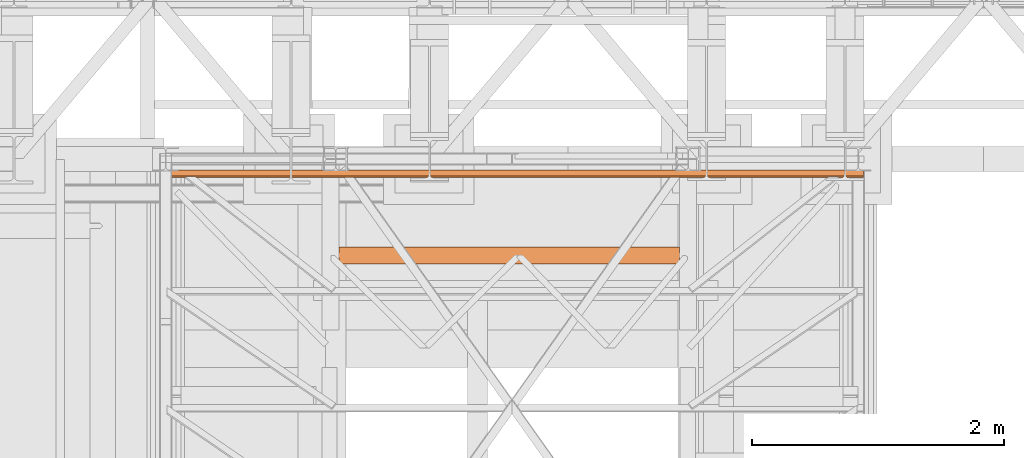
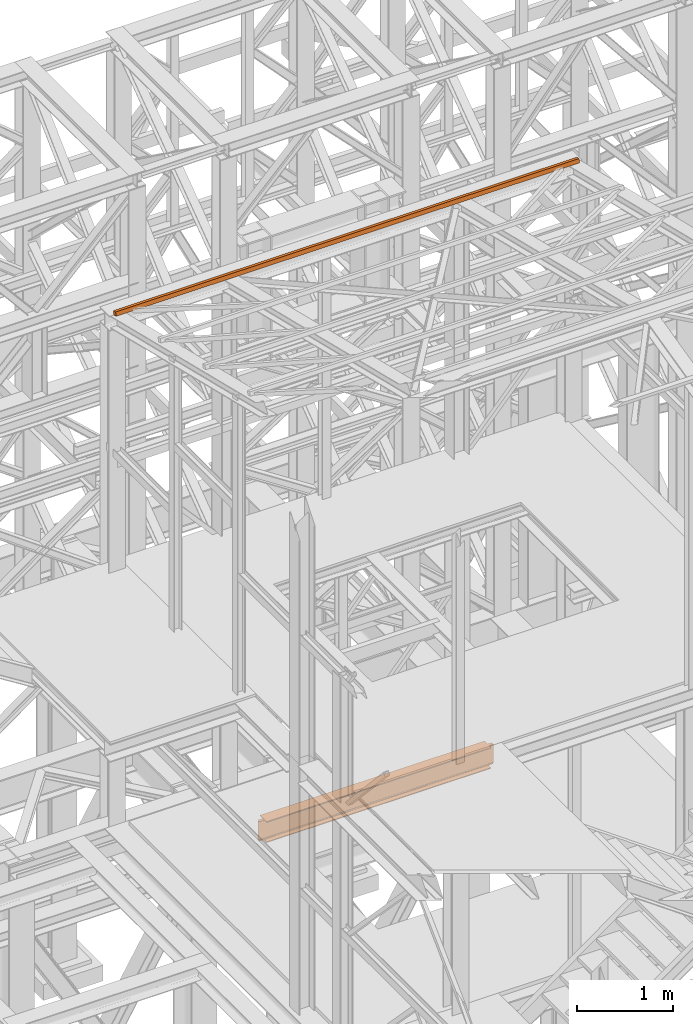
# One storey, part 73 of 208: 2 proxies.
"""IFC2X3 building model written with IfcOpenShell, lengths in millimetres."""

from ifc_helpers import new_model, entity, si_unit, converted_unit, frame, origin, origin_with_axes, place, context, subcontext, project, spatial, faceted_brep, element, save


model = new_model("IFC2X3")

# Units and contexts
model_context = context("Model", 3, precision=1e-05, world=origin())
plan_context = context("Plan", 3, precision=1e-05, world=origin())
body_context = subcontext(model_context, "Body", "Model", "MODEL_VIEW")
ifc_project = project(units=[si_unit("LENGTHUNIT", "METRE", prefix="MILLI"), converted_unit("PLANEANGLEUNIT", "DEGREE", entity("IfcPlaneAngleMeasure", 0.0174532925199433), si_unit("PLANEANGLEUNIT", "RADIAN"), dimensions=[0, 0, 0, 0, 0, 0, 0]), si_unit("AREAUNIT", "SQUARE_METRE"), si_unit("VOLUMEUNIT", "CUBIC_METRE")], contexts=[model_context, plan_context])

# Building, storey
building_placement = place(None, origin())
building = spatial("IfcBuilding", under=ifc_project, at=building_placement, CompositionType="COMPLEX")
storey_placement = place(building_placement, origin_with_axes())
storey = spatial("IfcBuildingStorey", under=building, at=storey_placement, Name="Geschoss", CompositionType="ELEMENT")

# Proxies
proxy_1_placement = place(storey_placement, frame((2509.054968290991, -18094.0743900329, 5014.990005364415), z_axis=(0.0, 0.0, 1.0), x_axis=(1.0, 0.0, 0.0)))
element("IfcBuildingElementProxy", 1, at=proxy_1_placement, inside=storey, context=body_context, shape_type="Brep", body=[
    faceted_brep([(2767.710000047684, 135.010000000002, 270.0100000000002), (64.21000004768393, 135.0100000000057, 270.0100000000002), (64.21000004768393, 135.0100000000057, 259.8100001907351), (2767.710000047684, 135.010000000002, 259.8100001907351), (2767.710000047684, 135.010000000002, 259.8100001907351), (64.21000004768393, 135.0100000000057, 259.8100001907351), (64.21000004768393, 85.80999995232196, 259.8100001907351), (2767.710000047684, 85.80999995231832, 259.8100001907351), (2816.910000095368, 85.80999995231832, 259.810000190736), (2767.710000047684, 85.80999995231832, 259.8100001907351), (64.21000004768393, 85.80999995232196, 259.8100001907351), (15.01000000000022, 85.80999995232196, 259.8100001907351), (10.37476080785564, 81.17476076017556, 259.0757968253238), (2821.545239287512, 81.17476076017556, 259.0757968253238), (2821.545239287512, 81.17476076017556, 259.0757968253238), (10.37476080785564, 81.17476076017556, 259.0757968253238), (6.193236074555898, 76.99323602687582, 256.9452365592933), (2825.726764020814, 76.99323602687582, 256.9452365592924), (2825.726764020814, 76.99323602687582, 256.9452365592924), (6.193236074555898, 76.99323602687582, 256.9452365592933), (2.874763631445603, 73.6747635837637, 253.6267641161803), (2829.045236463926, 73.6747635837637, 253.6267641161803), (2829.045236463926, 73.6747635837637, 253.6267641161803), (2.874763631445603, 73.6747635837637, 253.6267641161803), (0.7442033654115221, 71.54420331773144, 249.4452393828797), (2831.175796729956, 71.54420331773144, 249.4452393828797), (2831.175796729956, 71.54420331773144, 249.4452393828797), (0.7442033654115221, 71.54420331773144, 249.4452393828797), (0.01000000000021828, 70.80999995232196, 244.8100001907351), (2831.910000095368, 70.80999995231832, 244.8100001907351), (2831.910000095368, 70.80999995231832, 244.8100001907351), (0.01000000000021828, 70.80999995232196, 244.8100001907351), (0.01000000000021828, 70.80999995232196, 25.20999980926536), (2831.910000095368, 70.80999995231832, 25.20999980926536), (2831.910000095368, 70.80999995231832, 25.20999980926536), (0.01000000000021828, 70.80999995232196, 25.20999980926536), (0.7442033654115221, 71.54420331773144, 20.57476061712077), (2831.086954581584, 71.54420331773144, 20.57476061712077), (2831.398843532872, 71.42493642729096, 21.32772715327792), (2831.086954581584, 71.54420331773144, 20.57476061712077), (0.7442033654115221, 71.54420331773144, 20.57476061712077), (2.874763631443784, 73.6747635837637, 16.39323588382013), (2828.889959772629, 73.6747635837637, 16.39323588382013), (2829.900340863042, 73.00383809969208, 17.71002168452014), (2828.889959772629, 73.6747635837637, 16.39323588382013), (2.874763631443784, 73.6747635837637, 16.39323588382013), (6.193236074555898, 76.99323602687582, 13.07476344070892), (2825.524398651729, 76.99323602687582, 13.07476344070892), (2827.516601813166, 75.46460137611575, 14.60339809146717), (2825.524398651729, 76.99323602687582, 13.07476344070892), (6.193236074555898, 76.99323602687582, 13.07476344070892), (10.37476080785564, 81.17476076017556, 10.94420317467666), (2821.330755367998, 81.17476076017556, 10.94420317467666), (2824.409978220114, 78.67149890047949, 12.21965904159242), (2821.330755367998, 81.17476076017556, 10.94420317467666), (10.37476080785564, 81.17476076017556, 10.94420317467666), (15.01000000000022, 85.80999995232196, 10.20999980926536), (64.21000004768393, 85.80999995232196, 10.20999980926536), (2767.710000047684, 85.80999995231832, 10.20999980926536), (2816.910000095368, 85.80999995231832, 10.20999980926536), (2820.792272751356, 82.58292004036775, 10.72115637176194), (2767.710000047684, 85.80999995231832, 10.20999980926536), (64.21000004768393, 85.80999995232196, 10.20999980926536), (64.21000004768393, 135.0100000000057, 10.20999980926536), (2767.710000047684, 135.010000000002, 10.20999980926536), (2767.710000047684, 135.010000000002, 10.20999980926536), (64.21000004768393, 135.0100000000057, 10.20999980926536), (64.21000004768393, 135.0100000000057, 0.01000000000021828), (2767.710000047684, 135.010000000002, 0.01000000000021828), (2767.710000047684, 135.010000000002, 0.01000000000021828), (64.21000004768393, 135.0100000000057, 0.01000000000021828), (64.21000004768393, 0.01000000000567525, 0.01000000000021828), (2767.710000047684, 0.01000000000203727, 0.01000000000021828), (2767.710000047684, 0.01000000000203727, 0.01000000000021828), (64.21000004768393, 0.01000000000567525, 0.01000000000021828), (64.21000004768393, 0.01000000000567525, 10.20999980926536), (2767.710000047684, 0.01000000000203727, 10.20999980926536), (2767.710000047684, 0.01000000000203727, 10.20999980926536), (64.21000004768393, 0.01000000000567525, 10.20999980926536), (64.21000004768393, 49.21000004768939, 10.20999980926536), (2767.710000047684, 49.21000004768575, 10.20999980926536), (2816.910000095368, 49.21000004768575, 10.20999980926536), (2767.710000047684, 49.21000004768575, 10.20999980926536), (64.21000004768393, 49.21000004768939, 10.20999980926536), (15.01000000000022, 49.21000004768939, 10.20999980926536), (11.78292008804783, 53.0922727036741, 10.72115637176194), (2820.792272751355, 53.0922727036741, 10.72115637176194), (2820.792272751355, 53.0922727036741, 10.72115637176194), (11.78292008804783, 53.0922727036741, 10.72115637176194), (10.37476080785564, 53.63075532031871, 10.94420317467757), (7.871498948159569, 56.70997817243551, 12.21965904159242), (2824.409978220114, 56.70997817243188, 12.21965904159242), (2824.409978220114, 56.70997817243188, 12.21965904159242), (7.871498948159569, 56.70997817243551, 12.21965904159242), (6.193236074555898, 57.82439860405066, 13.07476344070892), (4.664601423799468, 59.81660176548758, 14.60339809146717), (2827.516601813166, 59.81660176548394, 14.60339809146717), (2827.516601813166, 59.81660176548394, 14.60339809146717), (4.664601423799468, 59.81660176548758, 14.60339809146717), (2.874763631443784, 61.18995972495031, 16.39323588382013), (2.203838147373972, 62.20034081536142, 17.71002168452014), (2829.900340863042, 62.20034081536142, 17.71002168452014), (2829.900340863042, 62.20034081536142, 17.71002168452014), (2.203838147373972, 62.20034081536142, 17.71002168452014), (0.7442033654115221, 63.38695453390392, 20.57476061712077), (0.6249364749728556, 63.6988434851919, 21.32772715327792), (2831.398843532872, 63.6988434851919, 21.32772715327792), (2831.398843532872, 63.6988434851919, 21.32772715327792), (0.6249364749728556, 63.6988434851919, 21.32772715327792), (0.01000000000021828, 64.21000004768939, 25.20999980926536), (2831.910000095368, 64.21000004768575, 25.20999980926536), (2831.910000095368, 64.21000004768575, 25.20999980926536), (0.01000000000021828, 64.21000004768939, 25.20999980926536), (0.01000000000021828, 64.21000004768939, 244.8100001907351), (2831.910000095368, 64.21000004768575, 244.8100001907351), (2831.910000095368, 64.21000004768575, 244.8100001907351), (0.01000000000021828, 64.21000004768939, 244.8100001907351), (0.7442033654115221, 63.47579668227627, 249.4452393828797), (2831.175796729956, 63.47579668227627, 249.4452393828797), (2831.175796729956, 63.47579668227627, 249.4452393828797), (0.7442033654115221, 63.47579668227627, 249.4452393828797), (2.874763631443784, 61.34523641624401, 253.6267641161803), (2829.045236463926, 61.34523641624401, 253.6267641161803), (2829.045236463926, 61.34523641624401, 253.6267641161803), (2.874763631443784, 61.34523641624401, 253.6267641161803), (6.193236074555898, 58.02676397313553, 256.9452365592933), (2825.726764020814, 58.02676397313189, 256.9452365592924), (2825.726764020814, 58.02676397313189, 256.9452365592924), (6.193236074555898, 58.02676397313553, 256.9452365592933), (10.37476080785564, 53.84523923983215, 259.0757968253238), (2821.545239287512, 53.84523923983215, 259.0757968253238), (2821.545239287512, 53.84523923983215, 259.0757968253238), (10.37476080785564, 53.84523923983215, 259.0757968253238), (15.01000000000022, 49.21000004768939, 259.8100001907351), (64.21000004768393, 49.21000004768939, 259.8100001907351), (2767.710000047684, 49.21000004768575, 259.8100001907351), (2816.910000095368, 49.21000004768575, 259.8100001907351), (2767.710000047684, 49.21000004768575, 259.8100001907351), (64.21000004768393, 49.21000004768939, 259.8100001907351), (64.21000004768393, 0.01000000000567525, 259.8100001907351), (2767.710000047684, 0.01000000000203727, 259.8100001907351), (2767.710000047684, 0.01000000000203727, 259.8100001907351), (64.21000004768393, 0.01000000000567525, 259.8100001907351), (64.21000004768393, 0.01000000000567525, 270.0100000000002), (2767.710000047684, 0.01000000000203727, 270.0100000000002), (2767.710000047684, 0.01000000000203727, 270.0100000000002), (64.21000004768393, 0.01000000000567525, 270.0100000000002), (64.21000004768393, 135.0100000000057, 270.0100000000002), (2767.710000047684, 135.010000000002, 270.0100000000002), (2767.710000047684, 0.01000000000203727, 0.01000000000021828), (2767.710000047684, 0.01000000000203727, 10.20999980926536), (2767.710000047684, 49.21000004768575, 10.20999980926536), (2767.710000047684, 85.80999995231832, 10.20999980926536), (2767.710000047684, 135.010000000002, 10.20999980926536), (2767.710000047684, 135.010000000002, 0.01000000000021828), (2767.710000047684, 49.21000004768575, 10.20999980926536), (2816.910000095368, 49.21000004768575, 10.20999980926536), (2816.910000095368, 85.80999995231832, 10.20999980926536), (2767.710000047684, 85.80999995231832, 10.20999980926536), (2816.910000095368, 49.21000004768575, 10.20999980926536), (2820.792272751355, 53.0922727036741, 10.72115637176194), (2820.792272751356, 82.58292004036775, 10.72115637176194), (2816.910000095368, 85.80999995231832, 10.20999980926536), (2820.792272751355, 53.0922727036741, 10.72115637176194), (2824.409978220114, 56.70997817243188, 12.21965904159242), (2824.409978220114, 78.67149890047949, 12.21965904159242), (2821.330755367998, 81.17476076017556, 10.94420317467666), (2820.792272751356, 82.58292004036775, 10.72115637176194), (2824.409978220114, 56.70997817243188, 12.21965904159242), (2827.516601813166, 59.81660176548394, 14.60339809146717), (2827.516601813166, 75.46460137611575, 14.60339809146717), (2825.524398651729, 76.99323602687582, 13.07476344070892), (2824.409978220114, 78.67149890047949, 12.21965904159242), (2827.516601813166, 59.81660176548394, 14.60339809146717), (2829.900340863042, 62.20034081536142, 17.71002168452014), (2829.900340863042, 73.00383809969208, 17.71002168452014), (2828.889959772629, 73.6747635837637, 16.39323588382013), (2827.516601813166, 75.46460137611575, 14.60339809146717), (2829.900340863042, 62.20034081536142, 17.71002168452014), (2831.398843532872, 63.6988434851919, 21.32772715327792), (2831.398843532872, 71.42493642729096, 21.32772715327792), (2831.086954581584, 71.54420331773144, 20.57476061712077), (2829.900340863042, 73.00383809969208, 17.71002168452014), (2831.398843532872, 63.6988434851919, 21.32772715327792), (2831.910000095368, 64.21000004768575, 25.20999980926536), (2831.910000095368, 70.80999995231832, 25.20999980926536), (2831.398843532872, 71.42493642729096, 21.32772715327792), (2831.910000095368, 64.21000004768575, 25.20999980926536), (2831.910000095368, 64.21000004768575, 244.8100001907351), (2831.910000095368, 70.80999995231832, 244.8100001907351), (2831.910000095368, 70.80999995231832, 25.20999980926536), (2831.910000095368, 64.21000004768575, 244.8100001907351), (2831.175796729956, 63.47579668227627, 249.4452393828797), (2831.175796729956, 71.54420331773144, 249.4452393828797), (2831.910000095368, 70.80999995231832, 244.8100001907351), (2831.175796729956, 63.47579668227627, 249.4452393828797), (2829.045236463926, 61.34523641624401, 253.6267641161803), (2829.045236463926, 73.6747635837637, 253.6267641161803), (2831.175796729956, 71.54420331773144, 249.4452393828797), (2829.045236463926, 61.34523641624401, 253.6267641161803), (2825.726764020814, 58.02676397313189, 256.9452365592924), (2825.726764020814, 76.99323602687582, 256.9452365592924), (2829.045236463926, 73.6747635837637, 253.6267641161803), (2825.726764020814, 58.02676397313189, 256.9452365592924), (2821.545239287512, 53.84523923983215, 259.0757968253238), (2821.545239287512, 81.17476076017556, 259.0757968253238), (2825.726764020814, 76.99323602687582, 256.9452365592924), (2821.545239287512, 53.84523923983215, 259.0757968253238), (2816.910000095368, 49.21000004768575, 259.8100001907351), (2816.910000095368, 85.80999995231832, 259.810000190736), (2821.545239287512, 81.17476076017556, 259.0757968253238), (2816.910000095368, 49.21000004768575, 259.8100001907351), (2767.710000047684, 49.21000004768575, 259.8100001907351), (2767.710000047684, 85.80999995231832, 259.8100001907351), (2816.910000095368, 85.80999995231832, 259.810000190736), (2767.710000047684, 0.01000000000203727, 259.8100001907351), (2767.710000047684, 0.01000000000203727, 270.0100000000002), (2767.710000047684, 135.010000000002, 270.0100000000002), (2767.710000047684, 135.010000000002, 259.8100001907351), (2767.710000047684, 85.80999995231832, 259.8100001907351), (2767.710000047684, 49.21000004768575, 259.8100001907351), (64.21000004768393, 0.01000000000567525, 270.0100000000002), (64.21000004768393, 0.01000000000567525, 259.8100001907351), (64.21000004768393, 49.21000004768939, 259.8100001907351), (64.21000004768393, 85.80999995232196, 259.8100001907351), (64.21000004768393, 135.0100000000057, 259.8100001907351), (64.21000004768393, 135.0100000000057, 270.0100000000002), (64.21000004768393, 49.21000004768939, 259.8100001907351), (15.01000000000022, 49.21000004768939, 259.8100001907351), (15.01000000000022, 85.80999995232196, 259.8100001907351), (64.21000004768393, 85.80999995232196, 259.8100001907351), (15.01000000000022, 49.21000004768939, 259.8100001907351), (10.37476080785564, 53.84523923983215, 259.0757968253238), (10.37476080785564, 81.17476076017556, 259.0757968253238), (15.01000000000022, 85.80999995232196, 259.8100001907351), (10.37476080785564, 53.84523923983215, 259.0757968253238), (6.193236074555898, 58.02676397313553, 256.9452365592933), (6.193236074555898, 76.99323602687582, 256.9452365592933), (10.37476080785564, 81.17476076017556, 259.0757968253238), (6.193236074555898, 58.02676397313553, 256.9452365592933), (2.874763631443784, 61.34523641624401, 253.6267641161803), (2.874763631445603, 73.6747635837637, 253.6267641161803), (6.193236074555898, 76.99323602687582, 256.9452365592933), (2.874763631443784, 61.34523641624401, 253.6267641161803), (0.7442033654115221, 63.47579668227627, 249.4452393828797), (0.7442033654115221, 71.54420331773144, 249.4452393828797), (2.874763631445603, 73.6747635837637, 253.6267641161803), (0.7442033654115221, 63.47579668227627, 249.4452393828797), (0.01000000000021828, 64.21000004768939, 244.8100001907351), (0.01000000000021828, 70.80999995232196, 244.8100001907351), (0.7442033654115221, 71.54420331773144, 249.4452393828797), (0.01000000000021828, 64.21000004768939, 244.8100001907351), (0.01000000000021828, 64.21000004768939, 25.20999980926536), (0.01000000000021828, 70.80999995232196, 25.20999980926536), (0.01000000000021828, 70.80999995232196, 244.8100001907351), (0.01000000000021828, 64.21000004768939, 25.20999980926536), (0.6249364749728556, 63.6988434851919, 21.32772715327792), (0.7442033654115221, 63.38695453390392, 20.57476061712077), (0.7442033654115221, 71.54420331773144, 20.57476061712077), (0.01000000000021828, 70.80999995232196, 25.20999980926536), (0.7442033654115221, 63.38695453390392, 20.57476061712077), (2.203838147373972, 62.20034081536142, 17.71002168452014), (2.874763631443784, 61.18995972495031, 16.39323588382013), (2.874763631443784, 73.6747635837637, 16.39323588382013), (0.7442033654115221, 71.54420331773144, 20.57476061712077), (2.874763631443784, 61.18995972495031, 16.39323588382013), (4.664601423799468, 59.81660176548758, 14.60339809146717), (6.193236074555898, 57.82439860405066, 13.07476344070892), (6.193236074555898, 76.99323602687582, 13.07476344070892), (2.874763631443784, 73.6747635837637, 16.39323588382013), (6.193236074555898, 57.82439860405066, 13.07476344070892), (7.871498948159569, 56.70997817243551, 12.21965904159242), (10.37476080785564, 53.63075532031871, 10.94420317467757), (10.37476080785564, 81.17476076017556, 10.94420317467666), (6.193236074555898, 76.99323602687582, 13.07476344070892), (10.37476080785564, 53.63075532031871, 10.94420317467757), (11.78292008804783, 53.0922727036741, 10.72115637176194), (15.01000000000022, 49.21000004768939, 10.20999980926536), (15.01000000000022, 85.80999995232196, 10.20999980926536), (10.37476080785564, 81.17476076017556, 10.94420317467666), (15.01000000000022, 49.21000004768939, 10.20999980926536), (64.21000004768393, 49.21000004768939, 10.20999980926536), (64.21000004768393, 85.80999995232196, 10.20999980926536), (15.01000000000022, 85.80999995232196, 10.20999980926536), (64.21000004768393, 0.01000000000567525, 10.20999980926536), (64.21000004768393, 0.01000000000567525, 0.01000000000021828), (64.21000004768393, 135.0100000000057, 0.01000000000021828), (64.21000004768393, 135.0100000000057, 10.20999980926536), (64.21000004768393, 85.80999995232196, 10.20999980926536), (64.21000004768393, 49.21000004768939, 10.20999980926536)], [[[0, 1, 2, 3]], [[4, 5, 6, 7]], [[8, 9, 10, 11, 12, 13]], [[14, 15, 16, 17]], [[18, 19, 20, 21]], [[22, 23, 24, 25]], [[26, 27, 28, 29]], [[30, 31, 32, 33]], [[34, 35, 36, 37, 38]], [[39, 40, 41, 42, 43]], [[44, 45, 46, 47, 48]], [[49, 50, 51, 52, 53]], [[54, 55, 56, 57, 58, 59, 60]], [[61, 62, 63, 64]], [[65, 66, 67, 68]], [[69, 70, 71, 72]], [[73, 74, 75, 76]], [[77, 78, 79, 80]], [[81, 82, 83, 84, 85, 86]], [[87, 88, 89, 90, 91]], [[92, 93, 94, 95, 96]], [[97, 98, 99, 100, 101]], [[102, 103, 104, 105, 106]], [[107, 108, 109, 110]], [[111, 112, 113, 114]], [[115, 116, 117, 118]], [[119, 120, 121, 122]], [[123, 124, 125, 126]], [[127, 128, 129, 130]], [[131, 132, 133, 134, 135, 136]], [[137, 138, 139, 140]], [[141, 142, 143, 144]], [[145, 146, 147, 148]], [[149, 150, 151, 152, 153, 154]], [[155, 156, 157, 158]], [[159, 160, 161, 162]], [[163, 164, 165, 166, 167]], [[168, 169, 170, 171, 172]], [[173, 174, 175, 176, 177]], [[178, 179, 180, 181, 182]], [[183, 184, 185, 186]], [[187, 188, 189, 190]], [[191, 192, 193, 194]], [[195, 196, 197, 198]], [[199, 200, 201, 202]], [[203, 204, 205, 206]], [[207, 208, 209, 210]], [[211, 212, 213, 214]], [[215, 216, 217, 218, 219, 220]], [[221, 222, 223, 224, 225, 226]], [[227, 228, 229, 230]], [[231, 232, 233, 234]], [[235, 236, 237, 238]], [[239, 240, 241, 242]], [[243, 244, 245, 246]], [[247, 248, 249, 250]], [[251, 252, 253, 254]], [[255, 256, 257, 258, 259]], [[260, 261, 262, 263, 264]], [[265, 266, 267, 268, 269]], [[270, 271, 272, 273, 274]], [[275, 276, 277, 278, 279]], [[280, 281, 282, 283]], [[284, 285, 286, 287, 288, 289]]], orient=[[False], [False], [False], [False], [False], [False], [False], [False], [False], [False], [False], [False], [False], [False], [False], [False], [False], [False], [False], [False], [False], [False], [False], [False], [False], [False], [False], [False], [False], [False], [False], [False], [False], [False], [False], [False], [False], [False], [False], [False], [False], [False], [False], [False], [False], [False], [False], [False], [False], [False], [False], [False], [False], [False], [False], [False], [False], [False], [False], [False], [False], [False], [False], [False]]),
])
proxy_2_placement = place(storey_placement, frame((1157.254971121463, -17407.82949452251, 11785.77681726853), z_axis=(0.0, 0.0, 1.0), x_axis=(1.0, 0.0, 0.0)))
element("IfcBuildingElementProxy", 2, at=proxy_2_placement, inside=storey, context=body_context, shape_type="Brep", body=[
    faceted_brep([(5582.010002264973, 11.80406569683692, 60.39315927079588), (5582.010002264973, 60.39315927079224, 48.59909357395736), (5582.010002264973, 48.59909357395372, 0.01000000000021828), (5582.010002264973, 0.00999999999839929, 11.80406569683873), (0.01000000000021828, 60.39315927079224, 48.59909357395736), (0.01000000000021828, 11.80406569683692, 60.39315927079588), (0.01000000000021828, 0.00999999999839929, 11.80406569683873), (0.01000000000021828, 48.59909357395372, 0.01000000000021828), (5582.010002264973, 60.39315927079224, 48.59909357395736), (5582.010002264973, 11.80406569683692, 60.39315927079588), (0.01000000000021828, 11.80406569683692, 60.39315927079588), (0.01000000000021828, 60.39315927079224, 48.59909357395736), (5582.010002264973, 48.59909357395372, 0.01000000000021828), (5582.010002264973, 60.39315927079224, 48.59909357395736), (0.01000000000021828, 60.39315927079224, 48.59909357395736), (0.01000000000021828, 48.59909357395372, 0.01000000000021828), (5582.010002264973, 0.00999999999839929, 11.80406569683873), (5582.010002264973, 48.59909357395372, 0.01000000000021828), (0.01000000000021828, 48.59909357395372, 0.01000000000021828), (0.01000000000021828, 0.00999999999839929, 11.80406569683873), (5582.010002264973, 11.80406569683692, 60.39315927079588), (5582.010002264973, 0.00999999999839929, 11.80406569683873), (0.01000000000021828, 0.00999999999839929, 11.80406569683873), (0.01000000000021828, 11.80406569683692, 60.39315927079588)], [[[0, 1, 2, 3]], [[4, 5, 6, 7]], [[8, 9, 10, 11]], [[12, 13, 14, 15]], [[16, 17, 18, 19]], [[20, 21, 22, 23]]], orient=[[False], [False], [False], [False], [False], [False]]),
])

save(model, "model.ifc")
